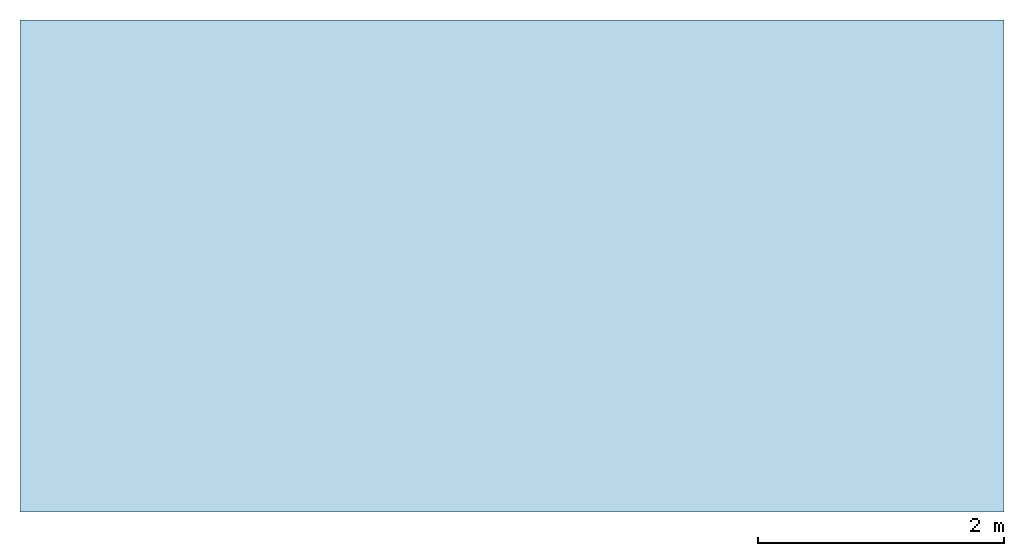
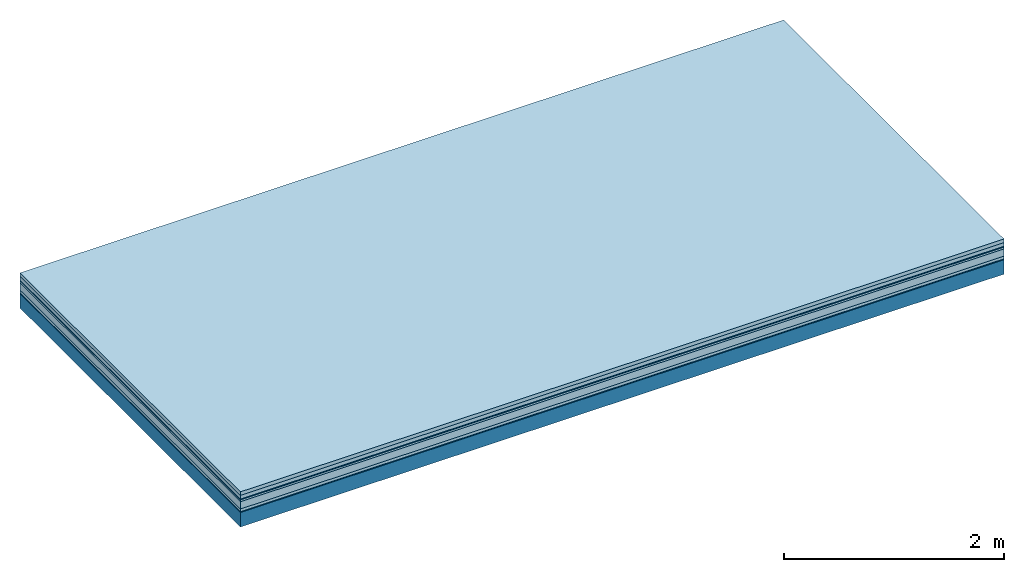
# One storey: 7 plates, 1 member, 1 element without a shape of its own.
"""IFC4 building model written with IfcOpenShell, lengths in metres."""

from ifc_helpers import new_model, si_unit, derived_unit, direction, frame, frame_2d, origin, origin_with_axes, place, context, project, spatial, rectangle, extrude, material, layer, layer_set, type_object, element, aggregate, save


model = new_model("IFC4")

# Units and contexts
plan_context = context("Plan", 3, precision=1e-05, world=origin(), true_north=direction((0.0, 1.0)))
model_context = context("Model", 3, precision=1e-05, world=origin(), true_north=direction((0.0, 1.0)))
ifc_project = project(units=[si_unit("LENGTHUNIT", "METRE"), derived_unit("SOUNDPRESSUREUNIT", [(si_unit("PRESSUREUNIT", "PASCAL", prefix="MICRO"), 0)]), si_unit("ENERGYUNIT", "JOULE", prefix="MEGA"), si_unit("MASSUNIT", "GRAM", prefix="KILO"), derived_unit("THERMALTRANSMITTANCEUNIT", [(si_unit("POWERUNIT", "WATT"), 1), (si_unit("AREAUNIT", "SQUARE_METRE"), -1), (si_unit("THERMODYNAMICTEMPERATUREUNIT", "KELVIN"), -1)]), derived_unit("AREADENSITYUNIT", [(si_unit("MASSUNIT", "GRAM", prefix="KILO"), 1), (si_unit("AREAUNIT", "SQUARE_METRE"), -1)]), derived_unit("USERDEFINED", [(si_unit("ENERGYUNIT", "JOULE", prefix="MEGA"), 1), (si_unit("AREAUNIT", "SQUARE_METRE"), -1)])], contexts=[plan_context, model_context])

# Site, building, storey
site = spatial("IfcSite", under=ifc_project)
building_placement = place(None, origin())
building = spatial("IfcBuilding", under=site, at=building_placement)
storey_placement = place(building_placement, origin())
storey = spatial("IfcBuildingStorey", under=building, at=storey_placement)

# Slab, member, plates
ifc_material_1 = material(Name="Garden plates", Category="02.007")
ifc_layer_1 = layer(ifc_material_1, 0.04, Name="Use and protection layer 3")
ifc_material_2 = material(Name="Gravel 8-16mm", Category="03.011")
ifc_layer_2 = layer(ifc_material_2, 0.04, Name="Use and protection layer 2")
ifc_material_3 = material(Name="Protective layer", Category="09.007")
ifc_layer_3 = layer(ifc_material_3, 0.01, Name="Use and protection layer 1")
ifc_material_4 = material(Name="Bituminous", Category="09.003")
ifc_layer_4 = layer(ifc_material_4, 0.02, Name="Seal")
ifc_material_5 = material(Category="10.006")
ifc_layer_5 = layer(ifc_material_5, 0.08, Name="Exterior insulation layer 2")
ifc_material_6 = material(Name="(034) 25 boards", Category="10.004")
ifc_layer_6 = layer(ifc_material_6, 0.03, Name="Exterior insulation layer 1")
ifc_material_7 = material(Name="Vapor-permeable barrier", Category="09.006")
ifc_layer_7 = layer(ifc_material_7, 0.01, Name="layer / temporary roof")
ifc_material_8 = material(Name="no composite action")
ifc_layer_8 = layer(ifc_material_8, 0.0, Name="Bond")
ifc_layer_9 = layer(None, 0.16, Name="Support")
ifc_layer_set = layer_set([ifc_layer_1, ifc_layer_2, ifc_layer_3, ifc_layer_4, ifc_layer_5, ifc_layer_6, ifc_layer_7, ifc_layer_8, ifc_layer_9])
slab_type = type_object("IfcSlabType", Name="F0058", PredefinedType="NOTDEFINED", material=ifc_layer_set)
slab_placement = place(None, frame((0.0, 0.0, 0.0), z_axis=(0.0, 0.0, -1.0), x_axis=(1.0, 0.0, 0.0)))
slab = element("IfcSlab", 1, at=slab_placement, inside=storey, type_object=slab_type, material=ifc_layer_set, Name="Slab #1")
ifc_material_9 = material(Name="Solid timber panel")
member_placement = place(slab_placement, origin())
member = element("IfcMember", 2, at=member_placement, material=ifc_material_9, Name="Support", context=plan_context, shape_type="SweptSolid", body=[
    extrude(rectangle(XDim=1.0, YDim=0.16, at=frame_2d((0.5, 0.08), x_axis=(1.0, 0.0))), frame((0.0, 4.0, 0.23), z_axis=(0.0, -1.0, 0.0), x_axis=(1.0, 0.0, 0.0)), (0.0, 0.0, 1.0), 4.0),
    extrude(rectangle(XDim=1.0, YDim=0.16, at=frame_2d((0.5, 0.08), x_axis=(1.0, 0.0))), frame((1.0, 4.0, 0.23), z_axis=(0.0, -1.0, 0.0), x_axis=(1.0, 0.0, 0.0)), (0.0, 0.0, 1.0), 4.0),
    extrude(rectangle(XDim=1.0, YDim=0.16, at=frame_2d((0.5, 0.08), x_axis=(1.0, 0.0))), frame((2.0, 4.0, 0.23), z_axis=(0.0, -1.0, 0.0), x_axis=(1.0, 0.0, 0.0)), (0.0, 0.0, 1.0), 4.0),
    extrude(rectangle(XDim=1.0, YDim=0.16, at=frame_2d((0.5, 0.08), x_axis=(1.0, 0.0))), frame((3.0, 4.0, 0.23), z_axis=(0.0, -1.0, 0.0), x_axis=(1.0, 0.0, 0.0)), (0.0, 0.0, 1.0), 4.0),
    extrude(rectangle(XDim=1.0, YDim=0.16, at=frame_2d((0.5, 0.08), x_axis=(1.0, 0.0))), frame((4.0, 4.0, 0.23), z_axis=(0.0, -1.0, 0.0), x_axis=(1.0, 0.0, 0.0)), (0.0, 0.0, 1.0), 4.0),
    extrude(rectangle(XDim=1.0, YDim=0.16, at=frame_2d((0.5, 0.08), x_axis=(1.0, 0.0))), frame((5.0, 4.0, 0.23), z_axis=(0.0, -1.0, 0.0), x_axis=(1.0, 0.0, 0.0)), (0.0, 0.0, 1.0), 4.0),
    extrude(rectangle(XDim=1.0, YDim=0.16, at=frame_2d((0.5, 0.08), x_axis=(1.0, 0.0))), frame((6.0, 4.0, 0.23), z_axis=(0.0, -1.0, 0.0), x_axis=(1.0, 0.0, 0.0)), (0.0, 0.0, 1.0), 4.0),
    extrude(rectangle(XDim=1.0, YDim=0.16, at=frame_2d((0.5, 0.08), x_axis=(1.0, 0.0))), frame((7.0, 4.0, 0.23), z_axis=(0.0, -1.0, 0.0), x_axis=(1.0, 0.0, 0.0)), (0.0, 0.0, 1.0), 4.0),
])
plate_1_placement = place(slab_placement, origin())
plate_1 = element("IfcPlate", 3, at=plate_1_placement, material=ifc_material_1, Name="Use and protection layer 3", context=plan_context, shape_type="SweptSolid", body=[
    extrude(rectangle(XDim=8.0, YDim=4.0, at=frame_2d((4.0, 2.0), x_axis=(1.0, 0.0))), origin_with_axes(), (0.0, 0.0, 1.0), 0.04),
])
plate_2_placement = place(slab_placement, origin())
plate_2 = element("IfcPlate", 4, at=plate_2_placement, material=ifc_material_2, Name="Use and protection layer 2", context=plan_context, shape_type="SweptSolid", body=[
    extrude(rectangle(XDim=8.0, YDim=4.0, at=frame_2d((4.0, 2.0), x_axis=(1.0, 0.0))), frame((0.0, 0.0, 0.04), z_axis=(0.0, 0.0, 1.0), x_axis=(1.0, 0.0, 0.0)), (0.0, 0.0, 1.0), 0.04),
])
plate_3_placement = place(slab_placement, origin())
plate_3 = element("IfcPlate", 5, at=plate_3_placement, material=ifc_material_3, Name="Use and protection layer 1", context=plan_context, shape_type="SweptSolid", body=[
    extrude(rectangle(XDim=8.0, YDim=4.0, at=frame_2d((4.0, 2.0), x_axis=(1.0, 0.0))), frame((0.0, 0.0, 0.08), z_axis=(0.0, 0.0, 1.0), x_axis=(1.0, 0.0, 0.0)), (0.0, 0.0, 1.0), 0.01),
])
plate_4_placement = place(slab_placement, origin())
plate_4 = element("IfcPlate", 6, at=plate_4_placement, material=ifc_material_4, Name="Seal", context=plan_context, shape_type="SweptSolid", body=[
    extrude(rectangle(XDim=8.0, YDim=4.0, at=frame_2d((4.0, 2.0), x_axis=(1.0, 0.0))), frame((0.0, 0.0, 0.09), z_axis=(0.0, 0.0, 1.0), x_axis=(1.0, 0.0, 0.0)), (0.0, 0.0, 1.0), 0.02),
])
plate_5_placement = place(slab_placement, origin())
plate_5 = element("IfcPlate", 7, at=plate_5_placement, material=ifc_material_5, Name="Exterior insulation layer 2", context=plan_context, shape_type="SweptSolid", body=[
    extrude(rectangle(XDim=8.0, YDim=4.0, at=frame_2d((4.0, 2.0), x_axis=(1.0, 0.0))), frame((0.0, 0.0, 0.11), z_axis=(0.0, 0.0, 1.0), x_axis=(1.0, 0.0, 0.0)), (0.0, 0.0, 1.0), 0.08),
])
plate_6_placement = place(slab_placement, origin())
plate_6 = element("IfcPlate", 8, at=plate_6_placement, material=ifc_material_6, Name="Exterior insulation layer 1", context=plan_context, shape_type="SweptSolid", body=[
    extrude(rectangle(XDim=8.0, YDim=4.0, at=frame_2d((4.0, 2.0), x_axis=(1.0, 0.0))), frame((0.0, 0.0, 0.19), z_axis=(0.0, 0.0, 1.0), x_axis=(1.0, 0.0, 0.0)), (0.0, 0.0, 1.0), 0.03),
])
plate_7_placement = place(slab_placement, origin())
plate_7 = element("IfcPlate", 9, at=plate_7_placement, material=ifc_material_7, Name="layer / temporary roof", context=plan_context, shape_type="SweptSolid", body=[
    extrude(rectangle(XDim=8.0, YDim=4.0, at=frame_2d((4.0, 2.0), x_axis=(1.0, 0.0))), frame((0.0, 0.0, 0.22), z_axis=(0.0, 0.0, 1.0), x_axis=(1.0, 0.0, 0.0)), (0.0, 0.0, 1.0), 0.01),
])
aggregate(slab, [plate_1, plate_2, plate_3, plate_4, plate_5, plate_6, plate_7, member])

save(model, "model.ifc")
